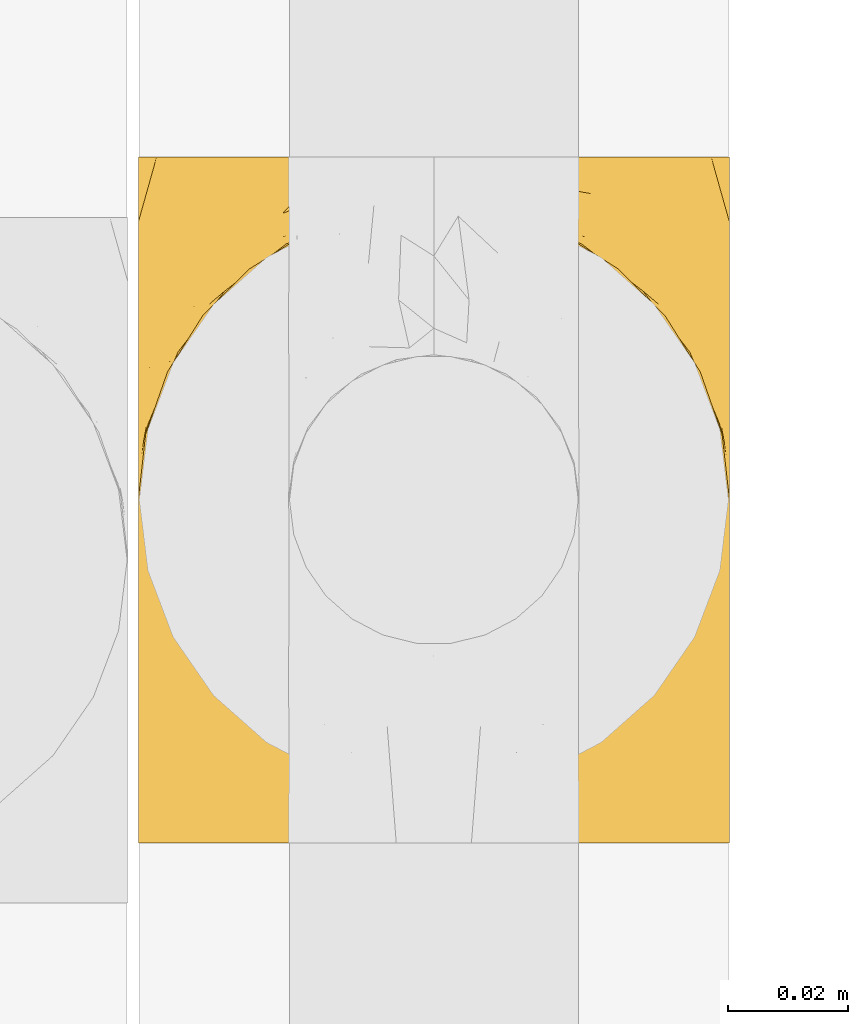
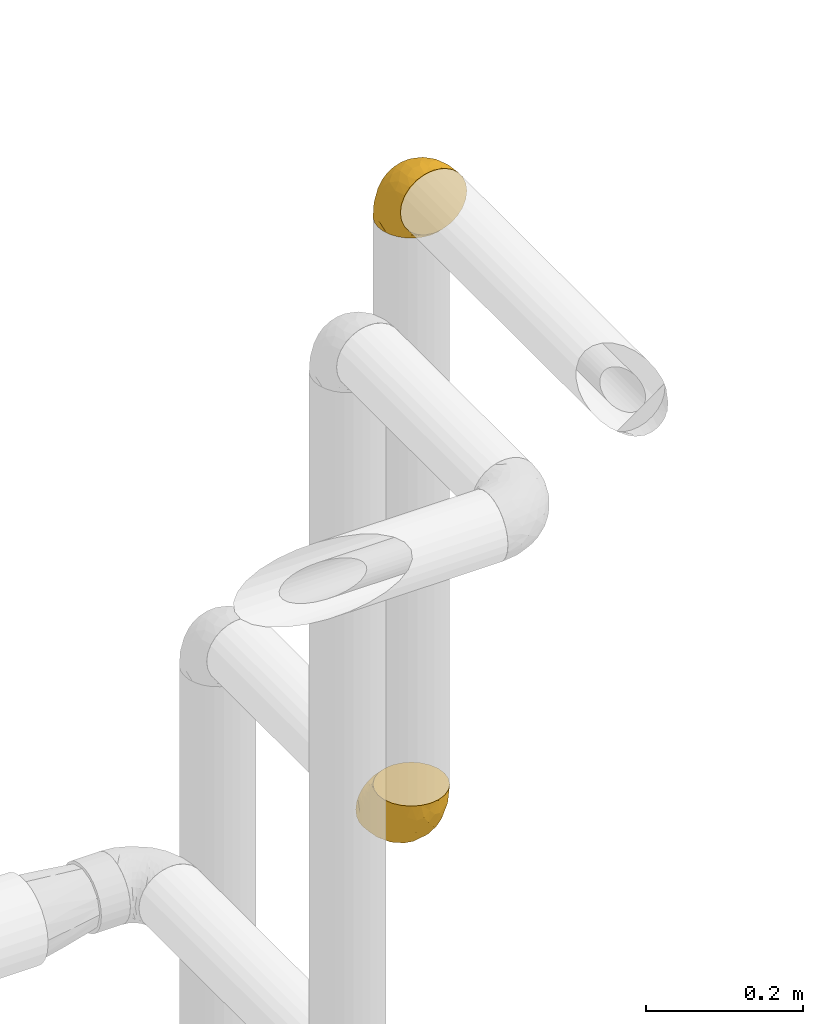
# One storey, part 416 of 824: 2 coverings.
"""IFC2X3 building model written with IfcOpenShell, lengths in millimetres."""

from ifc_helpers import new_model, entity, si_unit, converted_unit, derived_unit, direction, frame, origin, place, context, subcontext, project, spatial, faceted_brep, element, save


model = new_model("IFC2X3")

# Units and contexts
model_context = context("Model", 3, precision=0.01, world=origin(), true_north=direction((6.12303176911189e-17, 1.0)))
body_context = subcontext(model_context, "Body", "Model", "MODEL_VIEW")
ifc_project = project(units=[si_unit("LENGTHUNIT", "METRE", prefix="MILLI"), si_unit("AREAUNIT", "SQUARE_METRE"), si_unit("VOLUMEUNIT", "CUBIC_METRE"), converted_unit("PLANEANGLEUNIT", "DEGREE", entity("IfcRatioMeasure", 0.0174532925199433), si_unit("PLANEANGLEUNIT", "RADIAN"), dimensions=[0, 0, 0, 0, 0, 0, 0]), si_unit("MASSUNIT", "GRAM", prefix="KILO"), derived_unit("MASSDENSITYUNIT", [(si_unit("MASSUNIT", "GRAM", prefix="KILO"), 1), (si_unit("LENGTHUNIT", "METRE"), -3)]), derived_unit("MOMENTOFINERTIAUNIT", [(si_unit("LENGTHUNIT", "METRE"), 4)]), si_unit("TIMEUNIT", "SECOND"), si_unit("FREQUENCYUNIT", "HERTZ"), si_unit("THERMODYNAMICTEMPERATUREUNIT", "DEGREE_CELSIUS"), derived_unit("THERMALTRANSMITTANCEUNIT", [(si_unit("MASSUNIT", "GRAM", prefix="KILO"), 1), (si_unit("THERMODYNAMICTEMPERATUREUNIT", "KELVIN"), -1), (si_unit("TIMEUNIT", "SECOND"), -3)]), derived_unit("VOLUMETRICFLOWRATEUNIT", [(si_unit("LENGTHUNIT", "METRE"), 3), (si_unit("TIMEUNIT", "SECOND"), -1)]), derived_unit("MASSFLOWRATEUNIT", [(si_unit("MASSUNIT", "GRAM", prefix="KILO"), 1), (si_unit("TIMEUNIT", "SECOND"), -1)]), derived_unit("ROTATIONALFREQUENCYUNIT", [(si_unit("TIMEUNIT", "SECOND"), -1)]), si_unit("ELECTRICCURRENTUNIT", "AMPERE"), si_unit("ELECTRICVOLTAGEUNIT", "VOLT"), si_unit("POWERUNIT", "WATT"), si_unit("FORCEUNIT", "NEWTON", prefix="KILO"), si_unit("ILLUMINANCEUNIT", "LUX"), si_unit("LUMINOUSFLUXUNIT", "LUMEN"), si_unit("LUMINOUSINTENSITYUNIT", "CANDELA"), derived_unit("USERDEFINED", [(si_unit("MASSUNIT", "GRAM", prefix="KILO"), -1), (si_unit("LENGTHUNIT", "METRE"), -2), (si_unit("TIMEUNIT", "SECOND"), 3), (si_unit("LUMINOUSFLUXUNIT", "LUMEN"), 1)]), derived_unit("LINEARVELOCITYUNIT", [(si_unit("LENGTHUNIT", "METRE"), 1), (si_unit("TIMEUNIT", "SECOND"), -1)]), si_unit("PRESSUREUNIT", "PASCAL"), derived_unit("USERDEFINED", [(si_unit("LENGTHUNIT", "METRE"), -2), (si_unit("MASSUNIT", "GRAM", prefix="KILO"), 1), (si_unit("TIMEUNIT", "SECOND"), -2)]), derived_unit("LINEARFORCEUNIT", [(si_unit("MASSUNIT", "GRAM", prefix="KILO"), 1), (si_unit("LENGTHUNIT", "METRE"), 1), (si_unit("TIMEUNIT", "SECOND"), -2), (si_unit("LENGTHUNIT", "METRE"), -1)]), derived_unit("PLANARFORCEUNIT", [(si_unit("MASSUNIT", "GRAM", prefix="KILO"), 1), (si_unit("LENGTHUNIT", "METRE"), 1), (si_unit("TIMEUNIT", "SECOND"), -2), (si_unit("LENGTHUNIT", "METRE"), -2)])], contexts=[model_context])

# Site, building, storey
site_placement = place(None, origin())
site = spatial("IfcSite", under=ifc_project, at=site_placement, CompositionType="ELEMENT")
building_placement = place(site_placement, origin())
building = spatial("IfcBuilding", under=site, at=building_placement, CompositionType="ELEMENT")
storey_placement = place(building_placement, frame((0.0, 0.0, 28200.0)))
storey = spatial("IfcBuildingStorey", under=building, at=storey_placement, CompositionType="ELEMENT", Elevation=28200.0)

# Coverings
covering_1_placement = place(storey_placement, frame((50321.29, 18591.93, 2941.4)))
element("IfcCovering", 1, at=covering_1_placement, inside=storey, PredefinedType="INSULATION", context=body_context, shape_type="Brep", body=[
    faceted_brep([(1.6, 58.6, 1.6), (2.83, 69.54, 1.6), (6.47, 79.93, 1.6), (12.32, 89.25, 1.6), (20.11, 97.03, 1.6), (29.43, 102.88, 1.6), (39.81, 106.51, 1.6), (50.75, 107.75, 1.6), (61.69, 106.51, 1.6), (72.08, 102.87, 1.6), (81.4, 97.02, 1.6), (89.18, 89.23, 1.6), (95.03, 79.91, 1.6), (98.66, 69.53, 1.6), (99.9, 58.6, 1.6), (99.25, 52.89, 1.6), (98.66, 47.65, 1.6), (96.84, 42.46, 1.6), (95.02, 37.26, 1.6), (89.17, 27.94, 1.6), (81.38, 20.16, 1.6), (72.06, 14.31, 1.6), (61.68, 10.68, 1.6), (50.75, 9.45, 1.6), (39.8, 10.68, 1.6), (29.41, 14.32, 1.6), (20.09, 20.17, 1.6), (12.31, 27.96, 1.6), (6.46, 37.28, 1.6), (4.64, 42.47, 1.6), (2.83, 47.66, 1.6), (2.24, 52.89, 1.6), (1.92, 55.75, 1.6), (63.47, 1.6, 11.12), (75.32, 1.6, 16.03), (80.41, 1.6, 19.94), (85.5, 1.6, 23.84), (89.4, 1.6, 28.93), (93.31, 1.6, 34.02), (95.77, 1.6, 39.95), (98.22, 1.6, 45.87), (99.14, 1.6, 52.86), (99.52, 1.6, 55.73), (99.9, 1.6, 58.6), (98.22, 1.6, 71.32), (93.31, 1.6, 83.17), (85.5, 1.6, 93.35), (75.32, 1.6, 101.16), (63.47, 1.6, 106.07), (50.75, 1.6, 107.75), (38.02, 1.6, 106.07), (26.17, 1.6, 101.16), (15.99, 1.6, 93.35), (8.18, 1.6, 83.17), (3.27, 1.6, 71.32), (1.6, 1.6, 58.6), (2.35, 1.6, 52.86), (3.27, 1.6, 45.87), (5.73, 1.6, 39.95), (8.18, 1.6, 34.02), (12.09, 1.6, 28.93), (15.99, 1.6, 23.84), (21.08, 1.6, 19.94), (26.17, 1.6, 16.03), (38.02, 1.6, 11.12), (50.75, 1.6, 9.45), (42.18, 69.96, 81.82), (28.42, 59.59, 84.02), (37.78, 51.96, 93.05), (50.75, 34.4, 102.55), (42.85, 23.37, 104.83), (50.75, 13.68, 105.83), (24.75, 41.52, 91.87), (33.81, 26.26, 101.74), (22.57, 20.18, 97.07), (7.18, 72.33, 38.45), (2.73, 65.88, 22.17), (3.09, 57.55, 42.04), (6.92, 23.76, 77.69), (11.58, 46.5, 75.76), (5.17, 46.57, 62.11), (2.71, 21.17, 66.08), (1.6, 23.41, 54.26), (1.6, 17.92, 55.35), (1.6, 12.43, 56.44), (1.6, 9.72, 56.98), (1.6, 7.01, 57.52), (14.18, 26.77, 87.84), (5.88, 76.59, 19.41), (41.06, 95.55, 48.89), (36.25, 102.57, 26.34), (28.62, 92.89, 44.55), (1.6, 54.26, 23.41), (1.6, 51.17, 28.03), (1.6, 48.08, 32.65), (1.6, 44.99, 37.28), (1.6, 41.9, 41.9), (10.85, 85.16, 20.6), (38.35, 85.97, 63.36), (9.6, 59.58, 62.21), (26.24, 99.5, 19.94), (50.75, 105.83, 13.68), (19.31, 53.59, 80.85), (16.41, 67.0, 66.53), (24.56, 71.56, 71.06), (50.75, 87.47, 63.99), (50.75, 75.73, 75.73), (18.47, 92.24, 26.77), (1.6, 58.06, 4.31), (1.6, 57.52, 7.01), (1.6, 56.44, 12.43), (1.6, 55.35, 17.92), (14.36, 81.33, 43.43), (20.64, 80.35, 56.23), (2.32, 39.44, 54.97), (50.75, 102.55, 34.4), (1.6, 37.28, 44.99), (1.6, 32.65, 48.08), (1.6, 28.03, 51.17), (50.75, 63.99, 87.47), (33.88, 74.55, 74.55), (29.24, 83.62, 60.86), (50.75, 95.01, 49.19), (50.75, 49.19, 95.01), (2.8, 46.96, 10.27), (2.48, 8.77, 48.79), (2.7, 18.28, 45.16), (3.2, 11.68, 44.99), (32.98, 11.79, 6.17), (24.67, 15.69, 7.65), (2.95, 42.49, 21.59), (2.19, 47.41, 19.96), (17.92, 7.94, 21.0), (12.02, 9.27, 27.2), (25.73, 7.98, 14.83), (16.63, 13.4, 19.7), (25.6, 13.04, 10.93), (36.72, 7.36, 9.63), (10.66, 23.46, 19.97), (6.87, 30.46, 21.13), (11.12, 26.54, 14.14), (10.31, 6.76, 30.2), (12.84, 26.46, 8.12), (17.38, 20.77, 9.93), (9.74, 20.68, 24.62), (4.63, 40.26, 11.87), (50.75, 7.15, 7.15), (42.52, 9.28, 5.32), (3.12, 38.78, 26.68), (17.58, 18.27, 13.92), (3.97, 31.78, 30.67), (5.94, 12.75, 36.65), (2.73, 22.96, 42.89), (6.23, 17.55, 34.04), (3.45, 27.63, 36.6), (10.84, 15.23, 26.41), (7.98, 33.25, 10.07), (7.33, 32.43, 15.83), (2.39, 27.9, 41.99), (75.76, 7.97, 14.83), (90.65, 15.22, 26.4), (83.57, 7.93, 21.01), (84.85, 13.38, 19.71), (71.05, 13.12, 5.72), (98.54, 42.49, 21.6), (99.3, 47.4, 19.96), (99.9, 51.17, 28.03), (96.86, 40.24, 11.87), (84.1, 20.76, 9.93), (99.9, 12.43, 56.44), (99.9, 7.01, 57.52), (99.9, 4.31, 58.06), (88.63, 26.44, 8.13), (90.36, 26.52, 14.15), (98.29, 11.68, 44.99), (95.55, 12.75, 36.65), (89.47, 9.27, 27.21), (95.26, 17.55, 34.04), (91.18, 6.76, 30.2), (93.49, 33.21, 10.06), (94.15, 32.41, 15.83), (99.01, 8.77, 48.79), (98.76, 22.96, 42.89), (98.85, 18.48, 45.38), (99.9, 56.44, 12.43), (98.69, 46.95, 10.28), (64.78, 7.36, 9.64), (99.9, 17.92, 55.35), (99.9, 23.41, 54.26), (62.91, 9.85, 6.05), (99.9, 57.52, 7.01), (99.9, 56.98, 9.72), (99.9, 48.08, 32.65), (98.37, 38.78, 26.68), (83.9, 18.25, 13.92), (99.9, 44.99, 37.28), (97.51, 31.74, 30.66), (94.62, 30.45, 21.14), (98.04, 27.63, 36.59), (91.73, 20.65, 24.6), (99.9, 55.35, 17.92), (99.9, 54.26, 23.41), (75.87, 13.03, 10.93), (90.83, 23.44, 19.97), (99.1, 27.9, 41.99), (99.9, 32.65, 48.08), (99.9, 28.03, 51.17), (99.9, 37.28, 44.99), (99.9, 41.9, 41.9), (99.09, 39.74, 55.26), (58.64, 23.37, 104.83), (87.31, 26.77, 87.84), (89.93, 46.18, 75.91), (82.22, 53.54, 80.84), (76.74, 41.53, 91.87), (73.12, 59.61, 83.98), (95.54, 76.79, 19.16), (98.7, 66.11, 22.37), (98.79, 21.17, 66.08), (63.71, 51.96, 93.05), (67.68, 26.26, 101.74), (78.92, 20.18, 97.07), (94.57, 23.76, 77.69), (72.88, 92.88, 44.55), (65.25, 102.57, 26.34), (60.44, 95.54, 48.9), (76.94, 71.63, 70.99), (67.61, 74.55, 74.55), (94.38, 72.51, 37.8), (59.31, 69.96, 81.82), (83.03, 92.23, 26.77), (90.66, 85.15, 20.6), (80.8, 80.45, 56.15), (72.22, 83.65, 60.85), (98.39, 57.57, 42.06), (92.31, 63.68, 57.03), (63.11, 85.95, 63.4), (75.27, 99.49, 19.94), (87.15, 81.23, 43.59), (96.03, 47.07, 62.61), (85.1, 66.99, 66.52)], [[[0, 1, 2, 3, 4, 5, 6, 7, 8, 9, 10, 11, 12, 13, 14, 15, 16, 17, 18, 19, 20, 21, 22, 23, 24, 25, 26, 27, 28, 29, 30, 31, 32]], [[33, 34, 35, 36, 37, 38, 39, 40, 41, 42, 43, 44, 45, 46, 47, 48, 49, 50, 51, 52, 53, 54, 55, 56, 57, 58, 59, 60, 61, 62, 63, 64, 65]], [[66, 67, 68]], [[69, 70, 71]], [[68, 72, 73]], [[73, 72, 74]], [[75, 76, 77]], [[78, 79, 80]], [[51, 50, 73]], [[81, 82, 83, 84, 85, 86, 55]], [[52, 87, 53]], [[74, 52, 51]], [[2, 1, 88]], [[89, 90, 91]], [[77, 92, 93, 94, 95, 96]], [[55, 54, 81]], [[78, 53, 87]], [[5, 90, 6]], [[88, 76, 75]], [[97, 3, 2]], [[89, 91, 98]], [[99, 80, 79]], [[90, 5, 100]], [[74, 87, 52]], [[100, 5, 4]], [[90, 101, 6]], [[79, 102, 103]], [[102, 67, 104]], [[105, 98, 106]], [[107, 4, 3]], [[76, 0, 108, 109, 110, 111, 92]], [[107, 112, 113]], [[114, 77, 96]], [[89, 115, 90]], [[114, 96, 116, 117, 118, 82]], [[75, 97, 88]], [[119, 66, 68]], [[50, 71, 70]], [[100, 91, 90]], [[99, 77, 80]], [[102, 104, 103]], [[97, 107, 3]], [[80, 81, 78]], [[107, 97, 112]], [[68, 73, 70]], [[66, 98, 120]], [[78, 81, 54]], [[114, 81, 80]], [[53, 78, 54]], [[78, 87, 79]], [[102, 87, 72]], [[79, 103, 99]], [[4, 107, 100]], [[91, 100, 107]], [[88, 97, 2]], [[112, 97, 75]], [[99, 112, 75]], [[103, 104, 113]], [[91, 121, 98]], [[89, 105, 122, 115]], [[101, 90, 115]], [[101, 7, 6]], [[88, 1, 76]], [[0, 76, 1]], [[92, 77, 76]], [[73, 74, 51]], [[87, 74, 72]], [[81, 114, 82]], [[77, 114, 80]], [[87, 102, 79]], [[67, 102, 72]], [[68, 67, 72]], [[67, 120, 104]], [[120, 121, 104]], [[104, 121, 113]], [[121, 120, 98]], [[91, 107, 113]], [[91, 113, 121]], [[103, 113, 112]], [[106, 98, 66]], [[105, 89, 98]], [[106, 66, 119]], [[67, 66, 120]], [[68, 69, 123, 119]], [[50, 49, 71]], [[50, 70, 73]], [[112, 99, 103]], [[77, 99, 75]], [[69, 68, 70]], [[29, 124, 110]], [[84, 83, 125]], [[126, 82, 118]], [[59, 58, 127]], [[25, 128, 129]], [[130, 93, 131]], [[132, 62, 133]], [[134, 135, 136]], [[137, 65, 64]], [[64, 134, 137]], [[138, 139, 140]], [[111, 110, 124, 92]], [[134, 136, 137]], [[134, 64, 63]], [[141, 61, 60]], [[125, 58, 57]], [[142, 143, 140]], [[142, 26, 143]], [[127, 83, 82]], [[28, 124, 29]], [[108, 0, 32, 31, 30, 110, 109]], [[30, 29, 110]], [[135, 144, 138]], [[28, 145, 124]], [[57, 56, 55, 86, 85, 84]], [[146, 147, 23]], [[24, 23, 147]], [[25, 143, 26]], [[95, 94, 148]], [[24, 128, 25]], [[149, 138, 143]], [[124, 145, 131]], [[127, 58, 125]], [[150, 148, 139]], [[127, 126, 151]], [[151, 59, 127]], [[152, 151, 126]], [[153, 154, 155]], [[153, 133, 141]], [[145, 28, 27]], [[142, 156, 27]], [[157, 148, 130]], [[61, 133, 62]], [[134, 132, 135]], [[147, 128, 24]], [[65, 137, 146]], [[146, 137, 147]], [[128, 137, 136]], [[137, 128, 147]], [[128, 136, 129]], [[149, 129, 136]], [[25, 129, 143]], [[158, 152, 117]], [[152, 118, 117]], [[153, 151, 152]], [[158, 116, 154]], [[144, 150, 138]], [[153, 152, 158]], [[133, 153, 155]], [[133, 155, 132]], [[60, 151, 141]], [[135, 132, 155]], [[134, 63, 132]], [[144, 135, 155]], [[135, 138, 149]], [[155, 154, 144]], [[150, 154, 96]], [[154, 150, 144]], [[148, 94, 130]], [[82, 126, 127]], [[118, 152, 126]], [[150, 96, 95]], [[139, 148, 157]], [[150, 95, 148]], [[93, 92, 131]], [[130, 145, 156]], [[130, 94, 93]], [[84, 125, 57]], [[127, 125, 83]], [[140, 139, 157]], [[150, 139, 138]], [[140, 157, 142]], [[138, 140, 143]], [[156, 142, 157]], [[27, 26, 142]], [[130, 156, 157]], [[145, 27, 156]], [[132, 63, 62]], [[124, 131, 92]], [[130, 131, 145]], [[129, 149, 143]], [[135, 149, 136]], [[141, 133, 61]], [[60, 59, 151]], [[141, 151, 153]], [[116, 96, 154]], [[153, 158, 154]], [[158, 117, 116]], [[34, 33, 159]], [[160, 161, 162]], [[22, 21, 163]], [[164, 165, 166]], [[19, 18, 167]], [[168, 21, 20]], [[42, 41, 40, 169, 170, 171, 43]], [[172, 173, 168]], [[174, 38, 175]], [[176, 177, 178]], [[179, 164, 180]], [[40, 181, 169]], [[182, 183, 175]], [[17, 184, 185]], [[65, 146, 186]], [[187, 174, 188]], [[23, 22, 189]], [[174, 39, 38]], [[15, 14, 190, 191, 184, 16]], [[181, 40, 39]], [[192, 193, 164]], [[194, 163, 168]], [[33, 186, 159]], [[180, 173, 172]], [[195, 196, 193]], [[18, 185, 167]], [[173, 180, 197]], [[198, 199, 196]], [[200, 201, 185, 184]], [[184, 17, 16]], [[18, 17, 185]], [[202, 159, 186]], [[194, 168, 203]], [[189, 163, 202]], [[204, 205, 182]], [[187, 181, 174]], [[160, 177, 176]], [[206, 183, 182]], [[206, 182, 205]], [[201, 165, 185]], [[165, 164, 167]], [[172, 179, 180]], [[202, 194, 162]], [[176, 161, 160]], [[65, 186, 33]], [[163, 189, 22]], [[175, 177, 182]], [[174, 183, 188]], [[177, 198, 204]], [[199, 160, 162]], [[198, 207, 204]], [[175, 38, 37]], [[198, 177, 160]], [[178, 177, 175]], [[176, 35, 161]], [[34, 159, 161]], [[162, 161, 159]], [[202, 162, 159]], [[199, 162, 203]], [[196, 199, 203]], [[198, 160, 199]], [[193, 197, 180]], [[208, 198, 196]], [[188, 183, 206]], [[175, 183, 174]], [[193, 192, 195]], [[195, 208, 196]], [[197, 196, 203]], [[180, 164, 193]], [[168, 163, 21]], [[166, 165, 201]], [[166, 192, 164]], [[189, 202, 186]], [[186, 146, 189]], [[23, 189, 146]], [[174, 181, 39]], [[169, 181, 187]], [[196, 197, 193]], [[173, 203, 168]], [[203, 173, 197]], [[172, 168, 20]], [[20, 19, 172]], [[179, 172, 19]], [[19, 167, 179]], [[164, 179, 167]], [[35, 176, 36]], [[35, 34, 161]], [[185, 165, 167]], [[162, 194, 203]], [[163, 194, 202]], [[176, 178, 36]], [[37, 36, 178]], [[175, 37, 178]], [[177, 204, 182]], [[207, 198, 208]], [[207, 205, 204]], [[209, 188, 206, 205, 207, 208]], [[48, 210, 71]], [[211, 212, 213]], [[214, 213, 215]], [[216, 217, 13]], [[218, 43, 171, 170, 169, 187, 188]], [[219, 220, 214]], [[47, 46, 221]], [[210, 48, 220]], [[211, 222, 212]], [[222, 45, 44]], [[221, 220, 47]], [[47, 220, 48]], [[221, 211, 214]], [[223, 224, 225]], [[211, 46, 45]], [[226, 227, 215]], [[43, 218, 44]], [[217, 216, 228]], [[219, 215, 229]], [[14, 13, 217]], [[224, 9, 8]], [[10, 230, 11]], [[11, 231, 12]], [[232, 223, 233]], [[234, 208, 195, 192, 166, 201]], [[235, 234, 228]], [[222, 44, 218]], [[106, 229, 236]], [[224, 237, 9]], [[231, 238, 228]], [[9, 237, 10]], [[115, 224, 101]], [[239, 234, 235]], [[231, 11, 230]], [[223, 230, 237]], [[224, 8, 101]], [[223, 236, 233]], [[225, 115, 122, 105]], [[216, 12, 231]], [[209, 234, 239]], [[210, 219, 69]], [[219, 214, 215]], [[229, 119, 219]], [[209, 218, 188]], [[239, 212, 222]], [[239, 222, 218]], [[45, 222, 211]], [[235, 212, 239]], [[213, 212, 240]], [[223, 237, 224]], [[230, 10, 237]], [[238, 231, 230]], [[216, 231, 228]], [[232, 230, 223]], [[235, 238, 240]], [[115, 225, 224]], [[233, 236, 227]], [[8, 7, 101]], [[234, 209, 208]], [[218, 209, 239]], [[217, 228, 234]], [[13, 12, 216]], [[234, 201, 217]], [[217, 201, 200, 184, 191, 190, 14]], [[211, 221, 46]], [[220, 221, 214]], [[71, 210, 69]], [[71, 49, 48]], [[219, 210, 220]], [[226, 215, 213]], [[211, 213, 214]], [[226, 213, 240]], [[215, 227, 229]], [[232, 240, 238]], [[233, 227, 226]], [[232, 233, 226]], [[236, 223, 225]], [[240, 232, 226]], [[232, 238, 230]], [[225, 105, 236]], [[236, 105, 106]], [[236, 229, 227]], [[123, 69, 219, 119]], [[106, 119, 229]], [[238, 235, 228]], [[212, 235, 240]]]),
])
covering_2_placement = place(storey_placement, frame((50321.29, 18599.78, 1949.25)))
element("IfcCovering", 2, at=covering_2_placement, inside=storey, PredefinedType="INSULATION", context=body_context, shape_type="Brep", body=[
    faceted_brep([(99.9, 107.75, 50.75), (98.66, 107.75, 39.8), (95.02, 107.75, 29.41), (89.17, 107.75, 20.09), (81.38, 107.75, 12.31), (72.06, 107.75, 6.46), (61.68, 107.75, 2.83), (50.75, 107.75, 1.6), (39.8, 107.75, 2.83), (29.41, 107.75, 6.47), (20.09, 107.75, 12.32), (12.31, 107.75, 20.11), (6.46, 107.75, 29.43), (2.83, 107.75, 39.81), (1.6, 107.75, 50.75), (2.24, 107.75, 56.45), (2.83, 107.75, 61.69), (4.65, 107.75, 66.88), (6.47, 107.75, 72.08), (12.32, 107.75, 81.4), (20.11, 107.75, 89.18), (29.43, 107.75, 95.03), (39.81, 107.75, 98.66), (50.75, 107.75, 99.9), (61.69, 107.75, 98.66), (72.08, 107.75, 95.02), (81.4, 107.75, 89.17), (89.18, 107.75, 81.38), (95.03, 107.75, 72.06), (96.85, 107.75, 66.87), (98.66, 107.75, 61.68), (99.25, 107.75, 56.45), (99.57, 107.75, 53.6), (38.02, 98.22, 107.75), (26.17, 93.31, 107.75), (21.08, 89.4, 107.75), (15.99, 85.5, 107.75), (12.09, 80.41, 107.75), (8.18, 75.32, 107.75), (5.73, 69.39, 107.75), (3.27, 63.47, 107.75), (2.35, 56.48, 107.75), (1.97, 53.61, 107.75), (1.6, 50.75, 107.75), (3.27, 38.02, 107.75), (8.18, 26.17, 107.75), (15.99, 15.99, 107.75), (26.17, 8.18, 107.75), (38.02, 3.27, 107.75), (50.75, 1.6, 107.75), (63.47, 3.27, 107.75), (75.32, 8.18, 107.75), (85.5, 15.99, 107.75), (93.31, 26.17, 107.75), (98.22, 38.02, 107.75), (99.9, 50.75, 107.75), (99.14, 56.48, 107.75), (98.22, 63.47, 107.75), (95.77, 69.39, 107.75), (93.31, 75.32, 107.75), (89.4, 80.41, 107.75), (85.5, 85.5, 107.75), (80.41, 89.4, 107.75), (75.32, 93.31, 107.75), (63.47, 98.22, 107.75), (50.75, 99.9, 107.75), (59.31, 27.53, 39.38), (73.08, 25.32, 49.75), (63.72, 16.29, 57.38), (50.75, 6.79, 74.94), (58.64, 4.51, 85.97), (50.75, 3.51, 95.66), (76.74, 17.47, 67.82), (67.68, 7.6, 83.09), (78.92, 12.27, 89.16), (94.31, 70.89, 37.01), (98.76, 87.17, 43.46), (98.4, 67.3, 51.79), (94.57, 31.65, 85.58), (89.91, 33.58, 62.84), (96.32, 47.23, 62.77), (98.79, 43.26, 88.17), (99.9, 55.08, 85.93), (99.9, 53.99, 91.42), (99.9, 52.9, 96.91), (99.9, 52.36, 99.62), (99.9, 51.82, 102.33), (87.31, 21.5, 82.57), (95.61, 89.94, 32.75), (60.43, 60.45, 13.79), (65.24, 83.0, 6.77), (72.87, 64.79, 16.46), (99.9, 85.93, 55.08), (99.9, 81.31, 58.17), (99.9, 76.69, 61.26), (99.9, 72.06, 64.35), (99.9, 67.44, 67.44), (90.65, 88.74, 24.18), (63.14, 45.98, 23.37), (91.89, 47.13, 49.76), (75.25, 89.4, 9.84), (50.75, 95.66, 3.51), (82.18, 28.5, 55.75), (85.08, 42.81, 42.34), (76.93, 38.28, 37.78), (50.75, 45.35, 21.87), (50.75, 33.61, 33.61), (83.02, 82.57, 17.1), (99.9, 105.04, 51.28), (99.9, 102.33, 51.82), (99.9, 96.91, 52.9), (99.9, 91.42, 53.99), (87.13, 65.92, 28.01), (80.85, 53.11, 28.99), (99.17, 54.37, 69.9), (50.75, 74.94, 6.79), (99.9, 64.35, 72.06), (99.9, 61.26, 76.69), (99.9, 58.17, 81.31), (50.75, 21.87, 45.35), (67.61, 34.79, 34.79), (72.25, 48.48, 25.72), (50.75, 60.15, 14.33), (50.75, 14.33, 60.15), (98.69, 99.07, 62.38), (99.01, 60.55, 100.57), (98.79, 64.18, 91.06), (98.29, 64.36, 97.66), (68.51, 103.17, 97.55), (76.82, 101.69, 93.65), (98.54, 87.75, 66.85), (99.3, 89.38, 61.93), (83.57, 88.34, 101.4), (89.47, 82.14, 100.07), (75.76, 94.51, 101.36), (84.86, 89.64, 95.94), (75.89, 98.41, 96.3), (64.77, 99.71, 101.98), (90.83, 89.37, 85.88), (94.62, 88.21, 78.88), (90.37, 95.2, 82.8), (91.18, 79.14, 102.58), (88.65, 101.22, 82.88), (84.11, 99.41, 88.57), (91.75, 84.72, 88.67), (96.86, 97.47, 69.08), (50.75, 102.19, 102.19), (58.97, 104.02, 100.06), (98.37, 82.66, 70.56), (83.91, 95.42, 91.07), (97.52, 78.67, 77.56), (95.55, 72.69, 96.59), (98.76, 66.46, 86.38), (95.26, 75.3, 91.79), (98.04, 72.74, 81.71), (90.65, 82.93, 94.11), (93.51, 99.27, 76.09), (94.16, 93.51, 76.91), (99.1, 67.35, 81.44), (25.73, 94.51, 101.37), (10.84, 82.94, 94.12), (17.92, 88.33, 101.41), (16.64, 89.64, 95.96), (30.44, 103.62, 96.22), (2.95, 87.74, 66.85), (2.19, 89.38, 61.94), (1.6, 81.31, 58.17), (4.63, 97.47, 69.1), (17.39, 99.41, 88.58), (1.6, 51.28, 105.04), (1.6, 52.9, 96.91), (1.6, 51.82, 102.33), (12.86, 101.21, 82.9), (11.13, 95.19, 82.82), (3.2, 64.36, 97.66), (5.94, 72.69, 96.59), (12.02, 82.13, 100.07), (6.23, 75.3, 91.79), (10.31, 79.14, 102.58), (8.0, 99.28, 76.13), (7.34, 93.51, 76.93), (2.48, 60.55, 100.57), (2.73, 66.46, 86.38), (2.64, 63.96, 90.86), (1.6, 96.91, 52.9), (2.8, 99.06, 62.39), (36.71, 99.7, 101.98), (1.6, 53.99, 91.42), (1.6, 55.08, 85.93), (38.59, 103.3, 99.49), (1.6, 102.33, 51.82), (1.6, 99.62, 52.36), (1.6, 76.69, 61.26), (3.12, 82.66, 70.56), (17.59, 95.42, 91.09), (1.6, 72.06, 64.35), (3.98, 78.68, 77.6), (6.87, 88.2, 78.89), (3.45, 72.75, 81.71), (9.76, 84.74, 88.69), (1.6, 91.42, 53.99), (1.6, 85.93, 55.08), (25.62, 98.41, 96.31), (10.67, 89.37, 85.9), (2.39, 67.35, 81.45), (1.6, 61.26, 76.69), (1.6, 58.17, 81.31), (1.6, 64.35, 72.06), (1.6, 67.44, 67.44), (2.4, 54.08, 69.6), (42.85, 4.51, 85.97), (14.18, 21.5, 82.57), (11.56, 33.43, 63.16), (19.27, 28.5, 55.81), (24.75, 17.47, 67.81), (28.37, 25.36, 49.73), (5.95, 90.18, 32.55), (2.79, 86.97, 43.23), (2.71, 43.26, 88.17), (37.78, 16.29, 57.38), (33.81, 7.6, 83.08), (22.57, 12.27, 89.16), (6.92, 31.65, 85.58), (28.61, 64.79, 16.46), (36.24, 83.0, 6.77), (41.05, 60.44, 13.8), (24.55, 38.35, 37.71), (33.88, 34.8, 34.8), (7.11, 71.54, 36.83), (42.18, 27.53, 39.38), (18.46, 82.57, 17.12), (10.84, 88.74, 24.19), (20.69, 53.19, 28.89), (29.27, 48.49, 25.69), (3.1, 67.28, 51.77), (9.18, 52.32, 45.66), (38.38, 45.94, 23.39), (26.23, 89.4, 9.85), (14.34, 65.75, 28.11), (5.46, 46.73, 62.27), (16.39, 42.82, 42.35)], [[[0, 1, 2, 3, 4, 5, 6, 7, 8, 9, 10, 11, 12, 13, 14, 15, 16, 17, 18, 19, 20, 21, 22, 23, 24, 25, 26, 27, 28, 29, 30, 31, 32]], [[33, 34, 35, 36, 37, 38, 39, 40, 41, 42, 43, 44, 45, 46, 47, 48, 49, 50, 51, 52, 53, 54, 55, 56, 57, 58, 59, 60, 61, 62, 63, 64, 65]], [[66, 67, 68]], [[69, 70, 71]], [[68, 72, 73]], [[73, 72, 74]], [[75, 76, 77]], [[78, 79, 80]], [[51, 50, 73]], [[81, 82, 83, 84, 85, 86, 55]], [[52, 87, 53]], [[74, 52, 51]], [[2, 1, 88]], [[89, 90, 91]], [[77, 92, 93, 94, 95, 96]], [[55, 54, 81]], [[78, 53, 87]], [[5, 90, 6]], [[88, 76, 75]], [[97, 3, 2]], [[89, 91, 98]], [[99, 80, 79]], [[90, 5, 100]], [[74, 87, 52]], [[100, 5, 4]], [[90, 101, 6]], [[79, 102, 103]], [[102, 67, 104]], [[105, 98, 106]], [[107, 4, 3]], [[76, 0, 108, 109, 110, 111, 92]], [[107, 112, 113]], [[114, 77, 96]], [[89, 115, 90]], [[114, 96, 116, 117, 118, 82]], [[75, 97, 88]], [[119, 66, 68]], [[50, 71, 70]], [[100, 91, 90]], [[99, 77, 80]], [[102, 104, 103]], [[97, 107, 3]], [[80, 81, 78]], [[107, 97, 112]], [[68, 73, 70]], [[66, 98, 120]], [[78, 81, 54]], [[114, 81, 80]], [[53, 78, 54]], [[78, 87, 79]], [[102, 87, 72]], [[79, 103, 99]], [[4, 107, 100]], [[91, 100, 107]], [[88, 97, 2]], [[112, 97, 75]], [[99, 112, 75]], [[103, 104, 113]], [[91, 121, 98]], [[89, 105, 122, 115]], [[101, 90, 115]], [[101, 7, 6]], [[88, 1, 76]], [[0, 76, 1]], [[92, 77, 76]], [[73, 74, 51]], [[87, 74, 72]], [[81, 114, 82]], [[77, 114, 80]], [[87, 102, 79]], [[67, 102, 72]], [[68, 67, 72]], [[67, 120, 104]], [[120, 121, 104]], [[104, 121, 113]], [[121, 120, 98]], [[91, 107, 113]], [[91, 113, 121]], [[103, 113, 112]], [[66, 119, 106]], [[105, 89, 98]], [[68, 69, 123, 119]], [[67, 66, 120]], [[98, 66, 106]], [[50, 49, 71]], [[50, 70, 73]], [[112, 99, 103]], [[77, 99, 75]], [[69, 68, 70]], [[29, 124, 110]], [[84, 83, 125]], [[126, 82, 118]], [[59, 58, 127]], [[25, 128, 129]], [[130, 93, 131]], [[132, 62, 133]], [[134, 135, 136]], [[137, 65, 64]], [[64, 134, 137]], [[138, 139, 140]], [[111, 110, 124, 92]], [[134, 136, 137]], [[134, 64, 63]], [[133, 61, 141]], [[125, 58, 57]], [[142, 143, 140]], [[142, 26, 143]], [[127, 83, 82]], [[28, 124, 29]], [[108, 0, 32, 31, 30, 110, 109]], [[30, 29, 110]], [[135, 144, 138]], [[28, 145, 124]], [[57, 56, 55, 86, 85, 84]], [[146, 147, 23]], [[24, 23, 147]], [[25, 143, 26]], [[95, 94, 148]], [[24, 128, 25]], [[149, 138, 143]], [[124, 145, 131]], [[127, 58, 125]], [[150, 148, 139]], [[127, 126, 151]], [[151, 59, 127]], [[152, 151, 126]], [[153, 154, 155]], [[153, 133, 141]], [[145, 28, 27]], [[142, 156, 27]], [[157, 148, 130]], [[61, 133, 62]], [[134, 132, 135]], [[147, 128, 24]], [[65, 137, 146]], [[146, 137, 147]], [[128, 137, 136]], [[137, 128, 147]], [[128, 136, 129]], [[149, 129, 136]], [[25, 129, 143]], [[158, 152, 117]], [[152, 118, 117]], [[153, 151, 152]], [[158, 116, 154]], [[144, 150, 138]], [[153, 152, 158]], [[133, 153, 155]], [[133, 155, 132]], [[141, 61, 60]], [[135, 132, 155]], [[134, 63, 132]], [[144, 135, 155]], [[135, 138, 149]], [[155, 154, 144]], [[150, 154, 96]], [[154, 150, 144]], [[148, 94, 130]], [[82, 126, 127]], [[118, 152, 126]], [[150, 96, 95]], [[139, 148, 157]], [[150, 95, 148]], [[93, 92, 131]], [[130, 145, 156]], [[130, 94, 93]], [[84, 125, 57]], [[127, 125, 83]], [[140, 139, 157]], [[150, 139, 138]], [[140, 157, 142]], [[138, 140, 143]], [[156, 142, 157]], [[27, 26, 142]], [[130, 156, 157]], [[145, 27, 156]], [[132, 63, 62]], [[124, 131, 92]], [[130, 131, 145]], [[129, 149, 143]], [[135, 149, 136]], [[60, 151, 141]], [[59, 151, 60]], [[141, 151, 153]], [[116, 96, 154]], [[153, 158, 154]], [[158, 117, 116]], [[34, 33, 159]], [[160, 161, 162]], [[22, 21, 163]], [[164, 165, 166]], [[19, 18, 167]], [[168, 21, 20]], [[169, 43, 42, 41, 40, 170, 171]], [[172, 173, 168]], [[174, 38, 175]], [[176, 177, 178]], [[179, 164, 180]], [[40, 181, 170]], [[182, 183, 175]], [[17, 184, 185]], [[65, 146, 186]], [[187, 174, 188]], [[23, 22, 189]], [[174, 39, 38]], [[15, 14, 190, 191, 184, 16]], [[181, 40, 39]], [[192, 193, 164]], [[194, 163, 168]], [[33, 186, 159]], [[180, 173, 172]], [[195, 196, 193]], [[18, 185, 167]], [[173, 180, 197]], [[198, 199, 196]], [[200, 201, 185, 184]], [[184, 17, 16]], [[18, 17, 185]], [[202, 159, 186]], [[194, 168, 203]], [[189, 163, 202]], [[204, 205, 182]], [[187, 181, 174]], [[160, 177, 176]], [[206, 183, 182]], [[206, 182, 205]], [[201, 165, 185]], [[165, 164, 167]], [[172, 179, 180]], [[202, 194, 162]], [[176, 161, 160]], [[65, 186, 33]], [[163, 189, 22]], [[175, 177, 182]], [[174, 183, 188]], [[177, 198, 204]], [[199, 160, 162]], [[198, 207, 204]], [[175, 38, 37]], [[198, 177, 160]], [[178, 177, 175]], [[176, 35, 161]], [[34, 159, 161]], [[162, 161, 159]], [[202, 162, 159]], [[199, 162, 203]], [[196, 199, 203]], [[198, 160, 199]], [[193, 197, 180]], [[208, 198, 196]], [[188, 183, 206]], [[175, 183, 174]], [[193, 192, 195]], [[195, 208, 196]], [[197, 196, 203]], [[180, 164, 193]], [[168, 163, 21]], [[166, 165, 201]], [[166, 192, 164]], [[189, 202, 186]], [[186, 146, 189]], [[23, 189, 146]], [[174, 181, 39]], [[170, 181, 187]], [[196, 197, 193]], [[173, 203, 168]], [[203, 173, 197]], [[172, 168, 20]], [[20, 19, 172]], [[179, 172, 19]], [[19, 167, 179]], [[164, 179, 167]], [[35, 176, 36]], [[35, 34, 161]], [[185, 165, 167]], [[162, 194, 203]], [[163, 194, 202]], [[176, 178, 36]], [[37, 36, 178]], [[175, 37, 178]], [[177, 204, 182]], [[207, 198, 208]], [[207, 205, 204]], [[209, 188, 206, 205, 207, 208]], [[48, 210, 71]], [[211, 212, 213]], [[214, 213, 215]], [[216, 217, 13]], [[218, 43, 169, 171, 170, 187, 188]], [[219, 220, 214]], [[47, 46, 221]], [[210, 48, 220]], [[211, 222, 212]], [[222, 45, 44]], [[221, 220, 47]], [[47, 220, 48]], [[221, 211, 214]], [[223, 224, 225]], [[211, 46, 45]], [[226, 227, 215]], [[43, 218, 44]], [[217, 216, 228]], [[215, 229, 219]], [[14, 13, 217]], [[224, 9, 8]], [[10, 230, 11]], [[11, 231, 12]], [[232, 223, 233]], [[234, 208, 195, 192, 166, 201]], [[235, 234, 228]], [[222, 44, 218]], [[106, 229, 236]], [[224, 237, 9]], [[231, 238, 228]], [[9, 237, 10]], [[115, 224, 101]], [[239, 234, 235]], [[231, 11, 230]], [[223, 230, 237]], [[224, 8, 101]], [[223, 236, 233]], [[225, 115, 122, 105]], [[216, 12, 231]], [[209, 234, 239]], [[210, 219, 69]], [[219, 214, 215]], [[229, 119, 219]], [[209, 218, 188]], [[239, 212, 222]], [[239, 222, 218]], [[45, 222, 211]], [[235, 212, 239]], [[213, 212, 240]], [[223, 237, 224]], [[230, 10, 237]], [[238, 231, 230]], [[216, 231, 228]], [[232, 230, 223]], [[235, 238, 240]], [[115, 225, 224]], [[233, 236, 227]], [[8, 7, 101]], [[234, 209, 208]], [[218, 209, 239]], [[217, 228, 234]], [[13, 12, 216]], [[234, 201, 217]], [[217, 201, 200, 184, 191, 190, 14]], [[211, 221, 46]], [[220, 221, 214]], [[71, 210, 69]], [[71, 49, 48]], [[219, 210, 220]], [[226, 215, 213]], [[211, 213, 214]], [[226, 213, 240]], [[215, 227, 229]], [[232, 240, 238]], [[233, 227, 226]], [[232, 233, 226]], [[236, 223, 225]], [[240, 232, 226]], [[232, 238, 230]], [[225, 105, 236]], [[236, 105, 106]], [[229, 106, 119]], [[69, 219, 119, 123]], [[236, 229, 227]], [[238, 235, 228]], [[212, 235, 240]]]),
])

save(model, "model.ifc")
